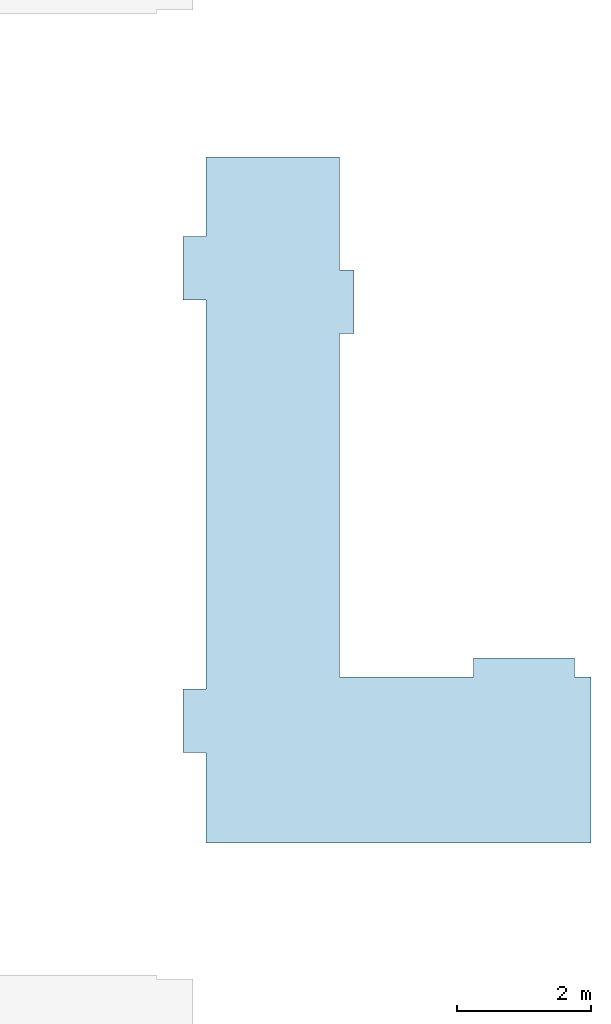
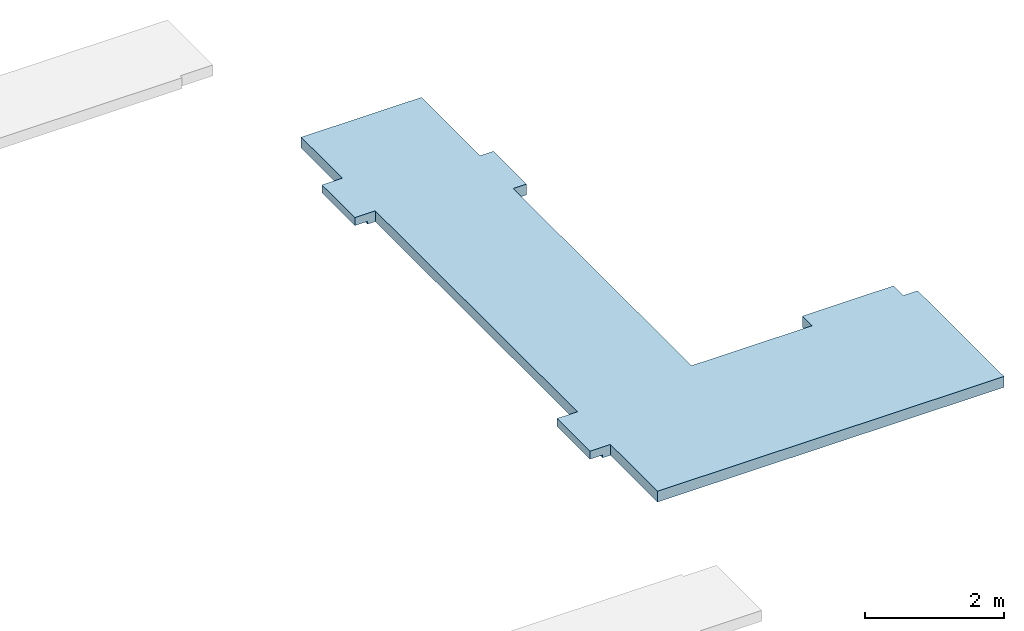
# One storey, part 2 of 2: 1 slab.
"""IFC2X3 building model written with IfcOpenShell, lengths in millimetres."""

from ifc_helpers import new_model, entity, si_unit, converted_unit, derived_unit, direction, frame, origin, place, context, subcontext, project, spatial, faceted_brep, material, material_list, type_object, element, save


model = new_model("IFC2X3")

# Units and contexts
model_context = context("Model", 3, precision=0.01, world=origin(), true_north=direction((6.12303176911189e-17, 1.0)))
body_context = subcontext(model_context, "Body", "Model", "MODEL_VIEW")
ifc_project = project(units=[si_unit("LENGTHUNIT", "METRE", prefix="MILLI"), si_unit("AREAUNIT", "SQUARE_METRE"), si_unit("VOLUMEUNIT", "CUBIC_METRE"), converted_unit("PLANEANGLEUNIT", "DEGREE", entity("IfcRatioMeasure", 0.0174532925199433), si_unit("PLANEANGLEUNIT", "RADIAN"), dimensions=[0, 0, 0, 0, 0, 0, 0]), si_unit("MASSUNIT", "GRAM", prefix="KILO"), derived_unit("MASSDENSITYUNIT", [(si_unit("MASSUNIT", "GRAM", prefix="KILO"), 1), (si_unit("LENGTHUNIT", "METRE"), -3)]), si_unit("TIMEUNIT", "SECOND"), si_unit("FREQUENCYUNIT", "HERTZ"), si_unit("THERMODYNAMICTEMPERATUREUNIT", "DEGREE_CELSIUS"), derived_unit("THERMALTRANSMITTANCEUNIT", [(si_unit("MASSUNIT", "GRAM", prefix="KILO"), 1), (si_unit("THERMODYNAMICTEMPERATUREUNIT", "KELVIN"), -1), (si_unit("TIMEUNIT", "SECOND"), -3)]), derived_unit("VOLUMETRICFLOWRATEUNIT", [(si_unit("LENGTHUNIT", "METRE"), 3), (si_unit("TIMEUNIT", "SECOND"), -1)]), si_unit("ELECTRICCURRENTUNIT", "AMPERE"), si_unit("ELECTRICVOLTAGEUNIT", "VOLT"), si_unit("POWERUNIT", "WATT"), si_unit("FORCEUNIT", "NEWTON", prefix="KILO"), si_unit("ILLUMINANCEUNIT", "LUX"), si_unit("LUMINOUSFLUXUNIT", "LUMEN"), si_unit("LUMINOUSINTENSITYUNIT", "CANDELA"), derived_unit("USERDEFINED", [(si_unit("MASSUNIT", "GRAM", prefix="KILO"), -1), (si_unit("LENGTHUNIT", "METRE"), -2), (si_unit("TIMEUNIT", "SECOND"), 3), (si_unit("LUMINOUSFLUXUNIT", "LUMEN"), 1)]), derived_unit("LINEARVELOCITYUNIT", [(si_unit("LENGTHUNIT", "METRE"), 1), (si_unit("TIMEUNIT", "SECOND"), -1)]), si_unit("PRESSUREUNIT", "PASCAL"), derived_unit("USERDEFINED", [(si_unit("LENGTHUNIT", "METRE"), -2), (si_unit("MASSUNIT", "GRAM", prefix="KILO"), 1), (si_unit("TIMEUNIT", "SECOND"), -2)])], contexts=[model_context])

# Site, building, storey
site_placement = place(None, origin())
site = spatial("IfcSite", under=ifc_project, at=site_placement, CompositionType="ELEMENT")
building_placement = place(site_placement, origin())
building = spatial("IfcBuilding", under=site, at=building_placement, CompositionType="ELEMENT")
storey_placement = place(building_placement, frame((0.0, 0.0, 4000.0)))
storey = spatial("IfcBuildingStorey", under=building, at=storey_placement, Name="01 Level", CompositionType="ELEMENT", Elevation=4000.0)

# Slab
ifc_material_1 = material(Name="07")
ifc_material_2 = material(Name="06")
ifc_material_3 = material(Name="02_Beton, C40/55")
ifc_material_4 = material(Name="04_XPS PLUS 30 SF")
ifc_material_list = material_list([ifc_material_1, ifc_material_2, ifc_material_3, ifc_material_4])
slab_type = type_object("IfcSlabType", Name="Floor", PredefinedType="FLOOR")
slab_placement = place(storey_placement, origin())
element("IfcSlab", 1, at=slab_placement, inside=storey, type_object=slab_type, material=ifc_material_list, Name="Floor", ObjectType="Floor", PredefinedType="FLOOR", context=body_context, shape_type="Brep", body=[
    faceted_brep([(30943.4900708518, -63785.8241905963, -190.0), (30943.4900708518, -65475.8241905964, -190.0), (31163.4900708518, -65475.8241905964, -190.0), (31163.4900708518, -66425.8241905964, -190.0), (30943.4900708518, -66425.8241905964, -190.0), (30943.4900708518, -71560.8241905963, -190.0), (31253.4900708518, -71560.8241905963, -190.0), (32947.6716011726, -71560.8241905963, -190.0), (32947.6716011726, -71280.8241905963, -190.0), (34463.4900708518, -71280.8241905963, -190.0), (34463.4900708518, -71560.8241905963, -190.0), (34703.4900708518, -71560.8241905963, -190.0), (34703.4900708518, -74045.8241905963, -190.0), (28943.4900708518, -74045.8241905963, -190.0), (28943.4900708518, -72691.23958514, -190.0), (28813.4900708518, -72691.23958514, -190.0), (28813.4900708518, -71741.23958514, -190.0), (28943.4900708518, -71741.23958514, -190.0), (28943.4900708518, -65921.2395851399, -190.0), (28813.4900708518, -65921.2395851399, -190.0), (28813.4900708518, -64971.2395851399, -190.0), (28943.4900708518, -64971.2395851399, -190.0), (28943.4900708518, -63785.8241905963, -190.0), (30943.4900708518, -65475.8241905964, 0.0), (30943.4900708518, -63785.8241905963, 0.0), (28943.4900708518, -63785.8241905963, 0.0), (28943.4900708518, -64971.2395851399, 0.0), (28603.4900708518, -64971.2395851399, 0.0), (28603.4900708518, -65921.2395851399, 0.0), (28943.4900708518, -65921.2395851399, 0.0), (28943.4900708518, -71741.23958514, 0.0), (28603.4900708518, -71741.2395851399, 0.0), (28603.4900708518, -72691.2395851399, 0.0), (28943.4900708518, -72691.23958514, 0.0), (28943.4900708518, -74045.8241905963, 0.0), (34703.4900708518, -74045.8241905963, 0.0), (34703.4900708518, -71560.8241905963, 0.0), (34463.4900708518, -71560.8241905963, 0.0), (34463.4900708518, -71280.8241905963, 0.0), (32947.6716011726, -71280.8241905963, 0.0), (32947.6716011726, -71560.8241905963, 0.0), (30943.4900708518, -71560.8241905963, 0.0), (30943.4900708518, -66425.8241905964, 0.0), (31163.4900708518, -66425.8241905964, 0.0), (31163.4900708518, -65475.8241905964, 0.0), (28603.4900708518, -72691.2395851399, -140.0), (28813.4900708518, -72691.23958514, -140.0), (28603.4900708518, -71741.2395851399, -140.0), (28813.4900708518, -71741.23958514, -140.0), (28603.4900708518, -65921.2395851399, -140.0), (28813.4900708518, -65921.2395851399, -140.0), (28603.4900708518, -64971.2395851399, -140.0), (28813.4900708518, -64971.2395851399, -140.0)], [[[0, 1, 2, 3, 4, 5, 6, 7, 8, 9, 10, 11, 12, 13, 14, 15, 16, 17, 18, 19, 20, 21, 22]], [[23, 24, 25, 26, 27, 28, 29, 30, 31, 32, 33, 34, 35, 36, 37, 38, 39, 40, 41, 42, 43, 44]], [[1, 0, 24, 23]], [[7, 6, 5, 41, 40]], [[12, 11, 36, 35]], [[13, 12, 35, 34]], [[14, 13, 34, 33]], [[0, 22, 25, 24]], [[8, 7, 40, 39]], [[9, 8, 39, 38]], [[10, 9, 38, 37]], [[11, 10, 37, 36]], [[33, 32, 45, 46, 15, 14]], [[32, 31, 47, 45]], [[31, 30, 17, 16, 48, 47]], [[18, 17, 30, 29]], [[29, 28, 49, 50, 19, 18]], [[28, 27, 51, 49]], [[27, 26, 21, 20, 52, 51]], [[22, 21, 26, 25]], [[52, 50, 49, 51]], [[50, 52, 20, 19]], [[2, 1, 23, 44]], [[3, 2, 44, 43]], [[4, 3, 43, 42]], [[5, 4, 42, 41]], [[46, 48, 16, 15]], [[48, 46, 45, 47]]]),
])

save(model, "model.ifc")
